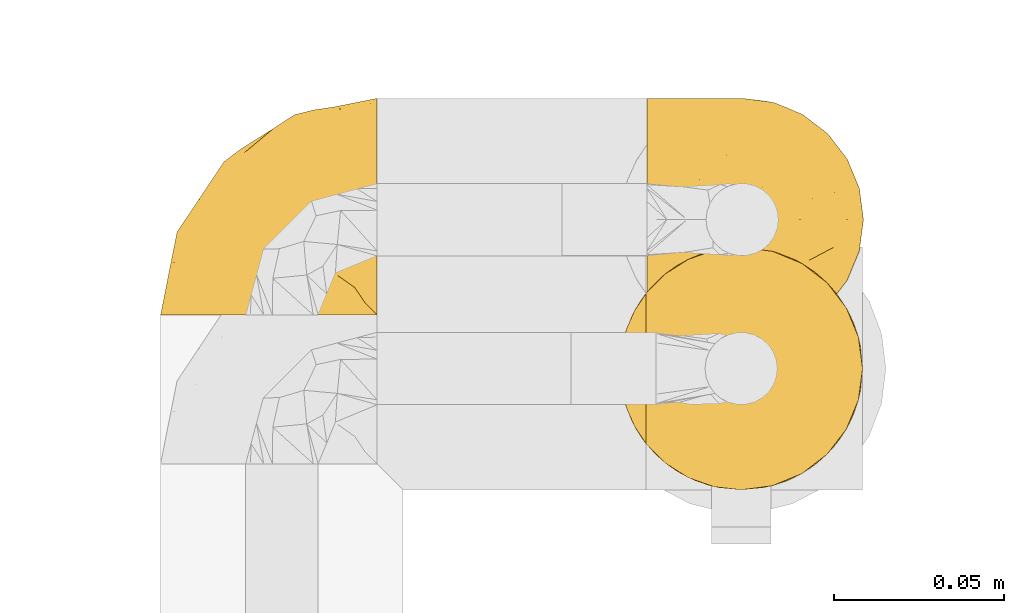
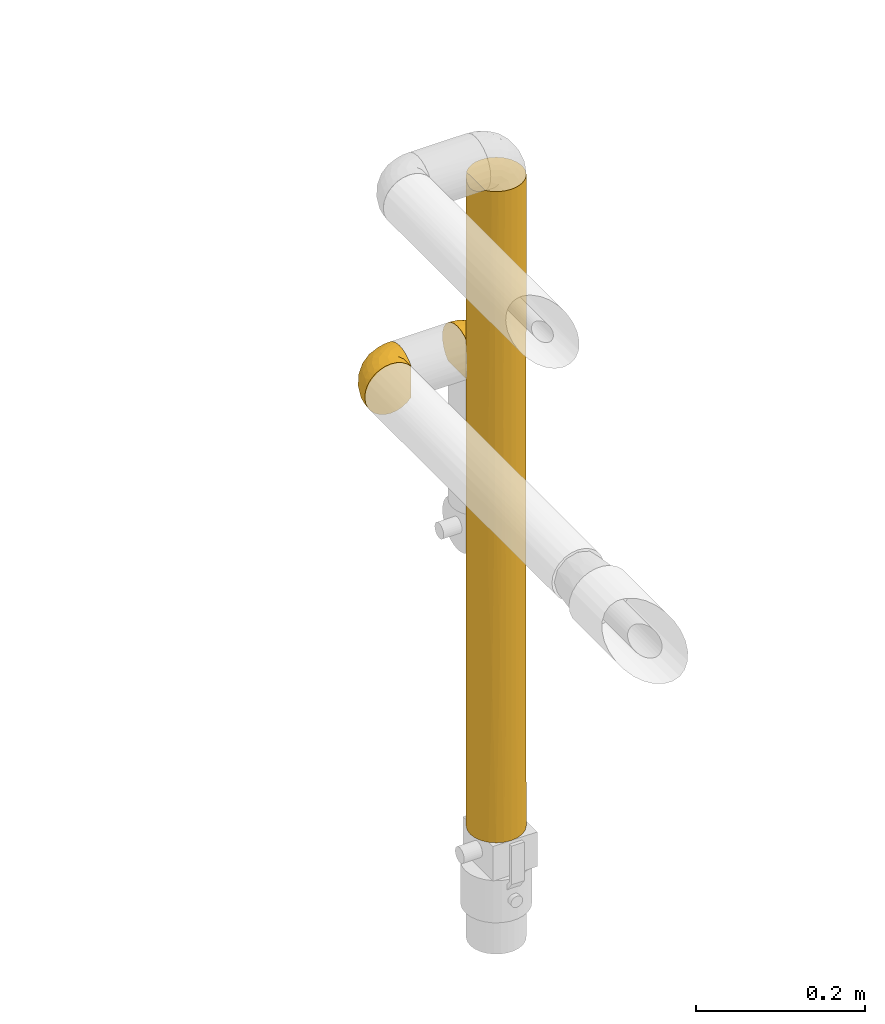
# One storey, part 68 of 827: 3 coverings.
"""IFC2X3 building model written with IfcOpenShell, lengths in millimetres."""

from ifc_helpers import new_model, entity, si_unit, converted_unit, derived_unit, direction, frame, origin, place, context, subcontext, project, spatial, faceted_brep, element, save


model = new_model("IFC2X3")

# Units and contexts
model_context = context("Model", 3, precision=0.01, world=origin(), true_north=direction((6.12303176911189e-17, 1.0)))
body_context = subcontext(model_context, "Body", "Model", "MODEL_VIEW")
ifc_project = project(units=[si_unit("LENGTHUNIT", "METRE", prefix="MILLI"), si_unit("AREAUNIT", "SQUARE_METRE"), si_unit("VOLUMEUNIT", "CUBIC_METRE"), converted_unit("PLANEANGLEUNIT", "DEGREE", entity("IfcRatioMeasure", 0.0174532925199433), si_unit("PLANEANGLEUNIT", "RADIAN"), dimensions=[0, 0, 0, 0, 0, 0, 0]), si_unit("MASSUNIT", "GRAM", prefix="KILO"), derived_unit("MASSDENSITYUNIT", [(si_unit("MASSUNIT", "GRAM", prefix="KILO"), 1), (si_unit("LENGTHUNIT", "METRE"), -3)]), derived_unit("MOMENTOFINERTIAUNIT", [(si_unit("LENGTHUNIT", "METRE"), 4)]), si_unit("TIMEUNIT", "SECOND"), si_unit("FREQUENCYUNIT", "HERTZ"), si_unit("THERMODYNAMICTEMPERATUREUNIT", "DEGREE_CELSIUS"), derived_unit("THERMALTRANSMITTANCEUNIT", [(si_unit("MASSUNIT", "GRAM", prefix="KILO"), 1), (si_unit("THERMODYNAMICTEMPERATUREUNIT", "KELVIN"), -1), (si_unit("TIMEUNIT", "SECOND"), -3)]), derived_unit("VOLUMETRICFLOWRATEUNIT", [(si_unit("LENGTHUNIT", "METRE"), 3), (si_unit("TIMEUNIT", "SECOND"), -1)]), derived_unit("MASSFLOWRATEUNIT", [(si_unit("MASSUNIT", "GRAM", prefix="KILO"), 1), (si_unit("TIMEUNIT", "SECOND"), -1)]), derived_unit("ROTATIONALFREQUENCYUNIT", [(si_unit("TIMEUNIT", "SECOND"), -1)]), si_unit("ELECTRICCURRENTUNIT", "AMPERE"), si_unit("ELECTRICVOLTAGEUNIT", "VOLT"), si_unit("POWERUNIT", "WATT"), si_unit("FORCEUNIT", "NEWTON", prefix="KILO"), si_unit("ILLUMINANCEUNIT", "LUX"), si_unit("LUMINOUSFLUXUNIT", "LUMEN"), si_unit("LUMINOUSINTENSITYUNIT", "CANDELA"), derived_unit("USERDEFINED", [(si_unit("MASSUNIT", "GRAM", prefix="KILO"), -1), (si_unit("LENGTHUNIT", "METRE"), -2), (si_unit("TIMEUNIT", "SECOND"), 3), (si_unit("LUMINOUSFLUXUNIT", "LUMEN"), 1)]), derived_unit("LINEARVELOCITYUNIT", [(si_unit("LENGTHUNIT", "METRE"), 1), (si_unit("TIMEUNIT", "SECOND"), -1)]), si_unit("PRESSUREUNIT", "PASCAL"), derived_unit("USERDEFINED", [(si_unit("LENGTHUNIT", "METRE"), -2), (si_unit("MASSUNIT", "GRAM", prefix="KILO"), 1), (si_unit("TIMEUNIT", "SECOND"), -2)]), derived_unit("LINEARFORCEUNIT", [(si_unit("MASSUNIT", "GRAM", prefix="KILO"), 1), (si_unit("LENGTHUNIT", "METRE"), 1), (si_unit("TIMEUNIT", "SECOND"), -2), (si_unit("LENGTHUNIT", "METRE"), -1)]), derived_unit("PLANARFORCEUNIT", [(si_unit("MASSUNIT", "GRAM", prefix="KILO"), 1), (si_unit("LENGTHUNIT", "METRE"), 1), (si_unit("TIMEUNIT", "SECOND"), -2), (si_unit("LENGTHUNIT", "METRE"), -2)])], contexts=[model_context])

# Site, building, storey
site_placement = place(None, origin())
site = spatial("IfcSite", under=ifc_project, at=site_placement, CompositionType="ELEMENT")
building_placement = place(site_placement, origin())
building = spatial("IfcBuilding", under=site, at=building_placement, CompositionType="ELEMENT")
storey_placement = place(building_placement, frame((0.0, 0.0, 28200.0)))
storey = spatial("IfcBuildingStorey", under=building, at=storey_placement, Name="08", CompositionType="ELEMENT", Elevation=28200.0)

# Coverings
covering_1_placement = place(storey_placement, frame((13380.77, 12385.32, 970.4)))
element("IfcCovering", 1, at=covering_1_placement, inside=storey, Name=":ADSK_", ObjectType=":ADSK_", PredefinedType="INSULATION", context=body_context, shape_type="Brep", body=[
    faceted_brep([(1.6, 5.13, 45.07), (1.6, 9.38, 51.83), (1.6, 15.03, 57.48), (1.6, 21.79, 61.72), (1.6, 29.32, 64.36), (1.6, 37.25, 65.25), (1.6, 45.19, 64.35), (1.6, 52.72, 61.71), (1.6, 59.48, 57.46), (1.6, 65.12, 51.82), (1.6, 69.37, 45.06), (1.6, 72.0, 37.52), (1.6, 72.9, 29.6), (1.6, 72.01, 21.69), (1.6, 69.39, 14.19), (1.6, 65.18, 7.45), (1.6, 59.59, 1.82), (1.6, 57.53, 1.82), (1.6, 56.06, 1.82), (1.6, 54.3, 1.82), (1.6, 52.53, 1.82), (1.6, 50.77, 1.82), (1.6, 49.0, 1.82), (1.6, 47.24, 1.82), (1.6, 45.47, 1.82), (1.6, 43.71, 1.82), (1.6, 41.94, 1.82), (1.6, 40.18, 1.82), (1.6, 38.41, 1.82), (1.6, 36.65, 1.82), (1.6, 34.88, 1.82), (1.6, 33.12, 1.82), (1.6, 31.35, 1.82), (1.6, 29.3, 1.82), (1.6, 27.24, 1.82), (1.6, 25.18, 1.82), (1.6, 23.13, 1.82), (1.6, 21.07, 1.82), (1.6, 19.01, 1.82), (1.6, 16.96, 1.82), (1.6, 14.9, 1.82), (1.6, 9.3, 7.46), (1.6, 5.09, 14.21), (1.6, 2.48, 21.71), (1.6, 1.6, 29.6), (1.6, 2.49, 37.54), (1.82, 59.59, 1.6), (7.46, 65.19, 1.6), (14.2, 69.4, 1.6), (21.7, 72.01, 1.6), (29.6, 72.9, 1.6), (38.82, 71.68, 1.6), (47.42, 68.12, 1.6), (54.8, 62.45, 1.6), (60.47, 55.07, 1.6), (64.03, 46.47, 1.6), (65.25, 37.25, 1.6), (64.03, 28.02, 1.6), (60.47, 19.42, 1.6), (54.8, 12.04, 1.6), (47.42, 6.37, 1.6), (38.82, 2.81, 1.6), (29.6, 1.6, 1.6), (21.7, 2.48, 1.6), (14.2, 5.09, 1.6), (7.46, 9.3, 1.6), (1.82, 14.9, 1.6), (1.82, 15.93, 1.6), (1.82, 17.69, 1.6), (1.82, 19.09, 1.6), (1.82, 20.49, 1.6), (1.82, 21.88, 1.6), (1.82, 23.28, 1.6), (1.82, 24.68, 1.6), (1.82, 26.07, 1.6), (1.82, 27.47, 1.6), (1.82, 28.87, 1.6), (1.82, 30.26, 1.6), (1.82, 31.66, 1.6), (1.82, 33.06, 1.6), (1.82, 34.45, 1.6), (1.82, 35.85, 1.6), (1.82, 37.25, 1.6), (1.82, 39.01, 1.6), (1.82, 40.77, 1.6), (1.82, 42.54, 1.6), (1.82, 44.3, 1.6), (1.82, 46.07, 1.6), (1.82, 47.83, 1.6), (1.82, 49.6, 1.6), (1.82, 51.36, 1.6), (1.82, 53.42, 1.6), (1.82, 55.48, 1.6), (1.82, 57.53, 1.6), (1.75, 24.13, 1.76), (1.76, 22.58, 1.75), (1.76, 46.76, 1.75), (1.76, 45.43, 1.75), (1.74, 51.49, 1.76), (1.76, 35.2, 1.75), (1.75, 58.19, 1.75), (1.75, 56.8, 1.75), (1.75, 32.4, 1.75), (1.76, 30.96, 1.75), (1.74, 16.26, 1.76), (1.75, 14.9, 1.76), (1.74, 28.17, 1.76), (1.76, 26.81, 1.75), (1.75, 55.49, 1.76), (1.75, 44.1, 1.76), (1.74, 42.83, 1.77), (1.76, 36.55, 1.74), (1.76, 37.92, 1.75), (1.76, 29.48, 1.75), (1.73, 39.3, 1.77), (1.74, 48.12, 1.77), (1.75, 49.39, 1.76), (1.74, 17.58, 1.76), (1.75, 33.81, 1.76), (1.78, 41.72, 1.72), (1.76, 54.15, 1.74), (1.76, 52.82, 1.75), (1.75, 40.57, 1.76), (1.76, 21.1, 1.75), (1.75, 19.79, 1.76), (1.75, 59.59, 1.75), (1.76, 25.46, 1.75), (13.11, 70.91, 13.1), (8.18, 68.25, 9.65), (25.84, 72.9, 15.6), (28.13, 72.9, 7.07), (15.6, 72.9, 25.84), (5.2, 64.57, 5.2), (20.72, 72.9, 20.72), (7.07, 72.9, 28.13), (35.56, 46.9, 53.84), (16.98, 49.03, 61.29), (25.95, 37.25, 60.4), (35.4, 72.16, 11.45), (32.74, 72.13, 18.37), (43.51, 65.96, 27.21), (53.51, 58.95, 23.34), (49.6, 65.53, 14.46), (40.07, 70.18, 17.53), (42.61, 70.18, 8.83), (20.45, 67.44, 44.61), (10.52, 67.44, 47.7), (14.87, 62.46, 53.12), (24.92, 72.2, 27.74), (34.61, 53.36, 51.46), (61.84, 43.86, 20.14), (60.43, 50.89, 17.45), (14.29, 37.25, 62.72), (57.0, 58.95, 11.49), (42.79, 55.84, 43.01), (33.34, 59.2, 47.84), (21.53, 71.35, 34.4), (11.52, 70.9, 40.11), (12.66, 56.22, 58.72), (34.11, 67.43, 35.5), (32.29, 70.63, 28.03), (24.41, 61.46, 50.73), (24.95, 56.22, 54.88), (44.19, 48.22, 46.54), (56.24, 51.43, 28.04), (56.83, 45.24, 31.36), (50.94, 50.08, 37.9), (50.38, 43.45, 41.63), (46.6, 37.25, 46.6), (36.28, 37.25, 53.5), (62.72, 37.25, 14.29), (47.39, 59.41, 33.68), (38.92, 62.46, 39.51), (29.55, 64.67, 43.99), (26.82, 68.36, 39.36), (60.4, 37.25, 25.96), (53.5, 37.25, 36.28), (41.8, 4.31, 12.43), (61.8, 30.45, 20.13), (49.33, 25.32, 40.53), (35.54, 27.6, 53.86), (14.87, 12.05, 53.13), (12.65, 18.29, 58.73), (47.44, 8.96, 20.81), (56.06, 15.54, 15.78), (50.17, 16.32, 31.16), (20.44, 7.07, 44.62), (10.52, 7.07, 47.72), (11.52, 3.6, 40.12), (38.79, 19.36, 47.19), (33.87, 2.28, 14.97), (25.84, 1.6, 15.6), (27.72, 1.6, 8.6), (7.07, 1.6, 28.13), (62.13, 25.07, 12.48), (50.52, 8.96, 10.34), (56.47, 29.09, 31.94), (58.39, 23.6, 23.68), (16.98, 25.48, 61.3), (39.3, 7.69, 31.19), (38.56, 4.1, 19.63), (24.94, 18.29, 54.9), (30.34, 2.18, 20.58), (26.49, 2.39, 26.9), (15.6, 1.6, 25.85), (20.72, 1.6, 20.72), (26.6, 12.04, 48.57), (21.54, 3.15, 34.41), (35.7, 2.24, 8.15), (38.91, 12.04, 39.53), (30.65, 6.5, 37.32), (44.9, 11.64, 31.82), (34.09, 3.92, 26.03), (13.11, 3.58, 13.11), (9.65, 6.24, 8.18), (5.2, 9.92, 5.21)], [[[0, 1, 2, 3, 4, 5, 6, 7, 8, 9, 10, 11, 12, 13, 14, 15, 16, 17, 18, 19, 20, 21, 22, 23, 24, 25, 26, 27, 28, 29, 30, 31, 32, 33, 34, 35, 36, 37, 38, 39, 40, 41, 42, 43, 44, 45]], [[46, 47, 48, 49, 50, 51, 52, 53, 54, 55, 56, 57, 58, 59, 60, 61, 62, 63, 64, 65, 66, 67, 68, 69, 70, 71, 72, 73, 74, 75, 76, 77, 78, 79, 80, 81, 82, 83, 84, 85, 86, 87, 88, 89, 90, 91, 92, 93]], [[94, 72, 95]], [[96, 87, 97]], [[20, 98, 21]], [[99, 81, 80]], [[100, 93, 101]], [[102, 103, 32]], [[104, 105, 40]], [[67, 105, 104]], [[106, 107, 34]], [[18, 101, 108]], [[109, 85, 110]], [[36, 94, 95]], [[81, 111, 82]], [[29, 28, 112]], [[17, 101, 18]], [[103, 113, 33]], [[24, 96, 97]], [[28, 114, 112]], [[115, 22, 116]], [[31, 102, 32]], [[68, 104, 117]], [[31, 118, 102]], [[84, 119, 85]], [[120, 91, 121]], [[23, 22, 115]], [[114, 27, 122]], [[123, 37, 95]], [[117, 124, 69]], [[67, 66, 105]], [[104, 39, 117]], [[123, 124, 37]], [[100, 17, 16]], [[100, 125, 46]], [[17, 100, 101]], [[107, 126, 35]], [[92, 108, 101]], [[115, 88, 96]], [[114, 122, 83]], [[101, 93, 92]], [[93, 100, 46]], [[16, 125, 100]], [[108, 19, 18]], [[120, 121, 19]], [[108, 92, 120]], [[19, 108, 120]], [[67, 104, 68]], [[39, 104, 40]], [[69, 68, 117]], [[117, 39, 38]], [[70, 124, 123]], [[124, 70, 69]], [[38, 124, 117]], [[124, 38, 37]], [[72, 71, 95]], [[71, 123, 95]], [[71, 70, 123]], [[126, 94, 35]], [[37, 36, 95]], [[75, 74, 107]], [[73, 72, 94]], [[94, 36, 35]], [[94, 126, 73]], [[74, 73, 126]], [[106, 76, 75]], [[76, 106, 113]], [[113, 106, 33]], [[107, 35, 34]], [[106, 34, 33]], [[126, 107, 74]], [[107, 106, 75]], [[78, 77, 103]], [[77, 113, 103]], [[77, 76, 113]], [[102, 78, 103]], [[33, 32, 103]], [[80, 79, 118]], [[102, 118, 79]], [[112, 111, 29]], [[118, 31, 30]], [[79, 78, 102]], [[99, 111, 81]], [[112, 82, 111]], [[111, 99, 29]], [[30, 29, 99]], [[112, 83, 82]], [[27, 114, 28]], [[99, 118, 30]], [[118, 99, 80]], [[114, 83, 112]], [[84, 83, 122]], [[109, 110, 25]], [[122, 27, 26]], [[119, 110, 85]], [[20, 19, 121]], [[25, 110, 26]], [[91, 120, 92]], [[90, 98, 121]], [[121, 91, 90]], [[23, 115, 96]], [[88, 115, 116]], [[116, 98, 89]], [[89, 88, 116]], [[23, 96, 24]], [[87, 96, 88]], [[25, 24, 109]], [[97, 87, 86]], [[90, 89, 98]], [[116, 22, 21]], [[122, 26, 119]], [[86, 85, 109]], [[109, 97, 86]], [[97, 109, 24]], [[110, 119, 26]], [[122, 119, 84]], [[121, 98, 20]], [[21, 98, 116]], [[48, 127, 49]], [[48, 47, 128]], [[49, 129, 130, 50]], [[129, 49, 127]], [[131, 127, 13]], [[46, 125, 132]], [[16, 15, 132]], [[127, 128, 14]], [[127, 131, 133, 129]], [[14, 13, 127]], [[13, 12, 134, 131]], [[46, 132, 47]], [[48, 128, 127]], [[47, 132, 128]], [[15, 128, 132]], [[125, 16, 132]], [[15, 14, 128]], [[135, 136, 137]], [[138, 129, 139]], [[140, 141, 142]], [[143, 144, 138]], [[145, 146, 147]], [[133, 148, 139]], [[134, 12, 11]], [[136, 135, 149]], [[150, 55, 151]], [[136, 6, 152]], [[153, 54, 53]], [[52, 144, 142]], [[52, 142, 53]], [[54, 153, 151]], [[144, 52, 51]], [[154, 155, 149]], [[156, 131, 157]], [[134, 11, 157]], [[8, 7, 158]], [[147, 9, 8]], [[157, 131, 134]], [[157, 11, 10]], [[146, 157, 10]], [[159, 140, 160]], [[157, 145, 156]], [[161, 162, 155]], [[161, 147, 162]], [[154, 149, 163]], [[150, 164, 165]], [[136, 7, 6]], [[137, 136, 152]], [[162, 158, 136]], [[54, 151, 55]], [[158, 147, 8]], [[166, 167, 165]], [[9, 146, 10]], [[164, 166, 165]], [[168, 135, 137, 169]], [[55, 150, 170]], [[154, 171, 172]], [[139, 148, 160]], [[140, 142, 143]], [[153, 142, 141]], [[51, 50, 130]], [[145, 173, 174]], [[156, 160, 148]], [[6, 5, 152]], [[136, 158, 7]], [[147, 158, 162]], [[147, 146, 9]], [[157, 146, 145]], [[160, 140, 143]], [[140, 172, 171]], [[139, 143, 138]], [[173, 159, 174]], [[170, 150, 175]], [[170, 56, 55]], [[167, 168, 176]], [[176, 175, 165]], [[150, 165, 175]], [[163, 167, 166]], [[176, 165, 167]], [[164, 150, 151]], [[151, 141, 164]], [[171, 164, 141]], [[154, 163, 166]], [[163, 135, 168]], [[166, 164, 171]], [[155, 154, 172]], [[166, 171, 154]], [[140, 171, 141]], [[173, 155, 172]], [[149, 155, 162]], [[159, 173, 172]], [[161, 145, 147]], [[140, 159, 172]], [[174, 160, 156]], [[136, 149, 162]], [[149, 135, 163]], [[155, 173, 161]], [[145, 161, 173]], [[160, 174, 159]], [[156, 148, 131]], [[156, 145, 174]], [[142, 153, 53]], [[151, 153, 141]], [[138, 51, 130]], [[142, 144, 143]], [[51, 138, 144]], [[129, 138, 130]], [[133, 139, 129]], [[160, 143, 139]], [[168, 167, 163]], [[131, 148, 133]], [[60, 177, 61]], [[175, 178, 170]], [[179, 168, 180]], [[178, 57, 170]], [[181, 182, 2]], [[183, 184, 185]], [[186, 187, 188]], [[189, 185, 179]], [[190, 191, 192]], [[45, 193, 188]], [[194, 184, 58]], [[45, 44, 193]], [[59, 195, 60]], [[60, 195, 177]], [[0, 45, 188]], [[196, 179, 197]], [[180, 137, 198]], [[183, 199, 200]], [[201, 182, 181]], [[1, 181, 2]], [[57, 178, 194]], [[198, 3, 182]], [[198, 152, 4]], [[1, 0, 187]], [[190, 202, 191]], [[203, 204, 205]], [[206, 201, 181]], [[186, 188, 207]], [[188, 204, 207]], [[3, 198, 4]], [[58, 184, 59]], [[187, 181, 1]], [[180, 198, 201]], [[206, 181, 186]], [[180, 189, 179]], [[3, 2, 182]], [[180, 168, 169, 137]], [[204, 188, 193]], [[177, 190, 208]], [[209, 210, 199]], [[210, 186, 207]], [[185, 184, 197]], [[195, 184, 183]], [[205, 202, 203]], [[210, 209, 206]], [[179, 185, 197]], [[211, 209, 199]], [[196, 197, 178]], [[180, 201, 189]], [[152, 198, 137]], [[152, 5, 4]], [[61, 208, 62]], [[198, 182, 201]], [[188, 187, 0]], [[181, 187, 186]], [[203, 210, 207]], [[202, 205, 191]], [[199, 210, 212]], [[57, 56, 170]], [[176, 196, 175]], [[178, 197, 194]], [[179, 176, 168]], [[175, 196, 178]], [[176, 179, 196]], [[184, 194, 197]], [[58, 57, 194]], [[208, 190, 192]], [[200, 190, 177]], [[206, 189, 201]], [[185, 189, 209]], [[62, 208, 192]], [[177, 208, 61]], [[210, 206, 186]], [[189, 206, 209]], [[200, 199, 212]], [[211, 183, 185]], [[184, 195, 59]], [[177, 195, 183]], [[183, 200, 177]], [[202, 200, 212]], [[200, 202, 190]], [[202, 212, 203]], [[210, 203, 212]], [[204, 203, 207]], [[183, 211, 199]], [[185, 209, 211]], [[63, 62, 192, 191]], [[64, 63, 213]], [[64, 213, 214]], [[65, 215, 66]], [[213, 191, 205, 204]], [[43, 204, 193, 44]], [[65, 214, 215]], [[42, 213, 43]], [[215, 105, 66]], [[41, 214, 42]], [[40, 105, 215]], [[65, 64, 214]], [[40, 215, 41]], [[213, 63, 191]], [[42, 214, 213]], [[204, 43, 213]], [[214, 41, 215]]]),
])
covering_2_placement = place(storey_placement, frame((13237.87, 12392.97, 962.76)))
element("IfcCovering", 2, at=covering_2_placement, inside=storey, Name=":ADSK_", ObjectType=":ADSK_", PredefinedType="INSULATION", context=body_context, shape_type="Brep", body=[
    faceted_brep([(21.77, 1.6, 69.36), (15.01, 1.6, 65.11), (9.37, 1.6, 59.47), (5.12, 1.6, 52.71), (2.49, 1.6, 45.17), (1.6, 1.6, 37.25), (2.49, 1.6, 29.31), (5.13, 1.6, 21.77), (9.38, 1.6, 15.01), (15.02, 1.6, 9.37), (21.78, 1.6, 5.12), (29.32, 1.6, 2.49), (37.25, 1.6, 1.6), (45.15, 1.6, 2.48), (52.65, 1.6, 5.1), (59.39, 1.6, 9.31), (65.02, 1.6, 14.9), (65.02, 1.6, 16.96), (65.02, 1.6, 18.43), (65.02, 1.6, 20.19), (65.02, 1.6, 21.96), (65.02, 1.6, 23.72), (65.02, 1.6, 25.49), (65.02, 1.6, 27.25), (65.02, 1.6, 29.02), (65.02, 1.6, 30.78), (65.02, 1.6, 32.55), (65.02, 1.6, 34.31), (65.02, 1.6, 36.08), (65.02, 1.6, 37.84), (65.02, 1.6, 39.61), (65.02, 1.6, 41.37), (65.02, 1.6, 43.14), (65.02, 1.6, 45.19), (65.02, 1.6, 47.25), (65.02, 1.6, 49.31), (65.02, 1.6, 51.36), (65.02, 1.6, 53.42), (65.02, 1.6, 55.48), (65.02, 1.6, 57.53), (65.02, 1.6, 59.59), (59.38, 1.6, 65.19), (52.64, 1.6, 69.4), (45.13, 1.6, 72.01), (37.25, 1.6, 72.9), (29.31, 1.6, 72.0), (65.25, 1.82, 14.9), (65.25, 7.46, 9.3), (65.25, 14.2, 5.09), (65.25, 21.7, 2.48), (65.25, 29.6, 1.6), (65.25, 38.82, 2.81), (65.25, 47.42, 6.37), (65.25, 54.8, 12.04), (65.25, 60.47, 19.42), (65.25, 64.03, 28.02), (65.25, 65.25, 37.25), (65.25, 64.03, 46.47), (65.25, 60.47, 55.07), (65.25, 54.8, 62.45), (65.25, 47.42, 68.12), (65.25, 38.82, 71.68), (65.25, 29.6, 72.9), (65.25, 21.7, 72.01), (65.25, 14.2, 69.4), (65.25, 7.46, 65.19), (65.25, 1.82, 59.59), (65.25, 1.82, 58.56), (65.25, 1.82, 56.8), (65.25, 1.82, 55.4), (65.25, 1.82, 54.0), (65.25, 1.82, 52.61), (65.25, 1.82, 51.21), (65.25, 1.82, 49.81), (65.25, 1.82, 48.42), (65.25, 1.82, 47.02), (65.25, 1.82, 45.62), (65.25, 1.82, 44.23), (65.25, 1.82, 42.83), (65.25, 1.82, 41.43), (65.25, 1.82, 40.04), (65.25, 1.82, 38.64), (65.25, 1.82, 37.25), (65.25, 1.82, 35.48), (65.25, 1.82, 33.72), (65.25, 1.82, 31.95), (65.25, 1.82, 30.19), (65.25, 1.82, 28.42), (65.25, 1.82, 26.66), (65.25, 1.82, 24.89), (65.25, 1.82, 23.13), (65.25, 1.82, 21.07), (65.25, 1.82, 19.01), (65.25, 1.82, 16.96), (65.08, 1.75, 50.36), (65.09, 1.76, 51.91), (65.09, 1.76, 27.73), (65.1, 1.76, 29.06), (65.08, 1.74, 23.0), (65.09, 1.76, 39.29), (65.09, 1.75, 16.3), (65.09, 1.75, 17.69), (65.09, 1.75, 42.09), (65.1, 1.76, 43.53), (65.08, 1.74, 58.23), (65.09, 1.75, 59.59), (65.08, 1.74, 46.32), (65.09, 1.76, 47.68), (65.08, 1.75, 19.0), (65.09, 1.75, 30.39), (65.07, 1.74, 31.67), (65.1, 1.76, 37.94), (65.09, 1.76, 36.57), (65.1, 1.76, 45.01), (65.07, 1.73, 35.19), (65.07, 1.74, 26.37), (65.09, 1.75, 25.1), (65.08, 1.74, 56.91), (65.09, 1.75, 40.68), (65.13, 1.78, 32.77), (65.1, 1.76, 20.34), (65.09, 1.76, 21.67), (65.09, 1.75, 33.92), (65.1, 1.76, 53.39), (65.09, 1.75, 54.7), (65.09, 1.75, 14.9), (65.09, 1.76, 49.03), (53.74, 13.11, 3.58), (57.19, 8.18, 6.24), (51.25, 25.84, 1.6), (59.77, 28.13, 1.6), (41.0, 15.6, 1.6), (61.64, 5.2, 9.92), (46.12, 20.72, 1.6), (38.71, 7.07, 1.6), (13.0, 35.56, 27.59), (5.55, 16.98, 25.47), (6.44, 25.95, 37.25), (55.39, 35.4, 2.33), (48.48, 32.74, 2.37), (39.63, 43.51, 8.53), (43.5, 53.51, 15.54), (52.38, 49.6, 8.96), (49.31, 40.07, 4.31), (58.01, 42.61, 4.31), (22.23, 20.45, 7.06), (19.14, 10.52, 7.06), (13.73, 14.87, 12.03), (39.1, 24.92, 2.3), (15.38, 34.61, 21.13), (46.7, 61.84, 30.63), (49.4, 60.43, 23.6), (4.12, 14.29, 37.25), (55.35, 57.0, 15.54), (23.83, 42.79, 18.65), (19.0, 33.34, 15.3), (32.44, 21.53, 3.14), (26.73, 11.52, 3.59), (8.12, 12.66, 18.27), (31.34, 34.11, 7.07), (38.81, 32.29, 3.86), (16.11, 24.41, 13.04), (11.96, 24.95, 18.27), (20.31, 44.19, 26.27), (38.81, 56.24, 23.06), (35.48, 56.83, 29.25), (28.94, 50.94, 24.41), (25.21, 50.38, 31.04), (20.24, 46.6, 37.25), (13.34, 36.28, 37.25), (52.55, 62.72, 37.25), (33.16, 47.39, 15.08), (27.33, 38.92, 12.03), (22.86, 29.55, 9.82), (27.48, 26.82, 6.14), (40.89, 60.4, 37.25), (30.56, 53.5, 37.25), (54.41, 41.8, 70.18), (46.71, 61.8, 44.04), (26.31, 49.33, 49.17), (12.98, 35.54, 46.9), (13.72, 14.87, 62.45), (8.12, 12.65, 56.21), (46.04, 47.44, 65.53), (51.06, 56.06, 58.95), (35.69, 50.17, 58.17), (22.22, 20.44, 67.43), (19.13, 10.52, 67.43), (26.72, 11.52, 70.89), (19.65, 38.79, 55.13), (51.87, 33.87, 72.21), (51.25, 25.84, 72.9), (58.25, 27.72, 72.9), (38.71, 7.07, 72.9), (54.36, 62.13, 49.42), (56.5, 50.52, 65.53), (34.9, 56.47, 45.41), (43.16, 58.39, 50.89), (5.54, 16.98, 49.01), (35.66, 39.3, 66.8), (47.21, 38.56, 70.39), (11.95, 24.94, 56.21), (46.27, 30.34, 72.31), (39.95, 26.49, 72.1), (41.0, 15.6, 72.9), (46.12, 20.72, 72.9), (18.27, 26.6, 62.45), (32.43, 21.54, 71.35), (58.69, 35.7, 72.26), (27.31, 38.91, 62.45), (29.52, 30.65, 67.99), (35.02, 44.9, 62.85), (40.81, 34.09, 70.57), (53.74, 13.11, 70.91), (58.66, 9.65, 68.25), (61.64, 5.2, 64.57)], [[[0, 1, 2, 3, 4, 5, 6, 7, 8, 9, 10, 11, 12, 13, 14, 15, 16, 17, 18, 19, 20, 21, 22, 23, 24, 25, 26, 27, 28, 29, 30, 31, 32, 33, 34, 35, 36, 37, 38, 39, 40, 41, 42, 43, 44, 45]], [[46, 47, 48, 49, 50, 51, 52, 53, 54, 55, 56, 57, 58, 59, 60, 61, 62, 63, 64, 65, 66, 67, 68, 69, 70, 71, 72, 73, 74, 75, 76, 77, 78, 79, 80, 81, 82, 83, 84, 85, 86, 87, 88, 89, 90, 91, 92, 93]], [[94, 72, 95]], [[96, 87, 97]], [[20, 98, 21]], [[99, 81, 80]], [[100, 93, 101]], [[102, 103, 32]], [[104, 105, 40]], [[67, 105, 104]], [[106, 107, 34]], [[18, 101, 108]], [[109, 85, 110]], [[36, 94, 95]], [[81, 111, 82]], [[29, 28, 112]], [[17, 101, 18]], [[103, 113, 33]], [[24, 96, 97]], [[28, 114, 112]], [[115, 22, 116]], [[31, 102, 32]], [[68, 104, 117]], [[31, 118, 102]], [[84, 119, 85]], [[120, 91, 121]], [[23, 22, 115]], [[114, 27, 122]], [[123, 37, 95]], [[117, 124, 69]], [[67, 66, 105]], [[104, 39, 117]], [[123, 124, 37]], [[100, 17, 16]], [[100, 125, 46]], [[17, 100, 101]], [[107, 126, 35]], [[92, 108, 101]], [[115, 88, 96]], [[114, 122, 83]], [[101, 93, 92]], [[93, 100, 46]], [[16, 125, 100]], [[108, 19, 18]], [[120, 121, 19]], [[108, 92, 120]], [[19, 108, 120]], [[67, 104, 68]], [[39, 104, 40]], [[69, 68, 117]], [[117, 39, 38]], [[70, 124, 123]], [[124, 70, 69]], [[38, 124, 117]], [[124, 38, 37]], [[72, 71, 95]], [[71, 123, 95]], [[71, 70, 123]], [[126, 94, 35]], [[37, 36, 95]], [[75, 74, 107]], [[73, 72, 94]], [[94, 36, 35]], [[94, 126, 73]], [[74, 73, 126]], [[106, 76, 75]], [[76, 106, 113]], [[113, 106, 33]], [[107, 35, 34]], [[106, 34, 33]], [[126, 107, 74]], [[107, 106, 75]], [[78, 77, 103]], [[77, 113, 103]], [[77, 76, 113]], [[102, 78, 103]], [[33, 32, 103]], [[80, 79, 118]], [[102, 118, 79]], [[112, 111, 29]], [[118, 31, 30]], [[79, 78, 102]], [[99, 111, 81]], [[112, 82, 111]], [[111, 99, 29]], [[30, 29, 99]], [[112, 83, 82]], [[27, 114, 28]], [[99, 118, 30]], [[118, 99, 80]], [[114, 83, 112]], [[84, 83, 122]], [[109, 110, 25]], [[122, 27, 26]], [[119, 110, 85]], [[20, 19, 121]], [[25, 110, 26]], [[91, 120, 92]], [[90, 98, 121]], [[121, 91, 90]], [[23, 115, 96]], [[88, 115, 116]], [[116, 98, 89]], [[89, 88, 116]], [[23, 96, 24]], [[87, 96, 88]], [[25, 24, 109]], [[97, 87, 86]], [[90, 89, 98]], [[116, 22, 21]], [[122, 26, 119]], [[86, 85, 109]], [[109, 97, 86]], [[97, 109, 24]], [[110, 119, 26]], [[122, 119, 84]], [[121, 98, 20]], [[21, 98, 116]], [[48, 127, 49]], [[48, 47, 128]], [[49, 129, 130, 50]], [[129, 49, 127]], [[131, 127, 13]], [[46, 125, 132]], [[16, 15, 132]], [[127, 128, 14]], [[127, 131, 133, 129]], [[14, 13, 127]], [[13, 12, 134, 131]], [[46, 132, 47]], [[48, 128, 127]], [[47, 132, 128]], [[15, 128, 132]], [[125, 16, 132]], [[15, 14, 128]], [[135, 136, 137]], [[138, 129, 139]], [[140, 141, 142]], [[143, 144, 138]], [[145, 146, 147]], [[133, 148, 139]], [[134, 12, 11]], [[136, 135, 149]], [[150, 55, 151]], [[136, 6, 152]], [[153, 54, 53]], [[52, 144, 142]], [[52, 142, 53]], [[54, 153, 151]], [[144, 52, 51]], [[154, 155, 149]], [[156, 131, 157]], [[134, 11, 157]], [[8, 7, 158]], [[147, 9, 8]], [[157, 131, 134]], [[157, 11, 10]], [[146, 157, 10]], [[159, 140, 160]], [[157, 145, 156]], [[161, 162, 155]], [[161, 147, 162]], [[154, 149, 163]], [[150, 164, 165]], [[136, 7, 6]], [[137, 136, 152]], [[162, 158, 136]], [[54, 151, 55]], [[158, 147, 8]], [[166, 167, 165]], [[9, 146, 10]], [[164, 166, 165]], [[168, 135, 137, 169]], [[55, 150, 170]], [[154, 171, 172]], [[139, 148, 160]], [[140, 142, 143]], [[153, 142, 141]], [[51, 50, 130]], [[145, 173, 174]], [[156, 160, 148]], [[6, 5, 152]], [[136, 158, 7]], [[147, 158, 162]], [[147, 146, 9]], [[157, 146, 145]], [[160, 140, 143]], [[140, 172, 171]], [[139, 143, 138]], [[173, 159, 174]], [[170, 150, 175]], [[170, 56, 55]], [[167, 168, 176]], [[176, 175, 165]], [[150, 165, 175]], [[163, 167, 166]], [[176, 165, 167]], [[164, 150, 151]], [[151, 141, 164]], [[171, 164, 141]], [[154, 163, 166]], [[163, 135, 168]], [[166, 164, 171]], [[155, 154, 172]], [[166, 171, 154]], [[140, 171, 141]], [[173, 155, 172]], [[149, 155, 162]], [[159, 173, 172]], [[161, 145, 147]], [[140, 159, 172]], [[174, 160, 156]], [[136, 149, 162]], [[149, 135, 163]], [[155, 173, 161]], [[145, 161, 173]], [[160, 174, 159]], [[156, 148, 131]], [[156, 145, 174]], [[142, 153, 53]], [[151, 153, 141]], [[138, 51, 130]], [[142, 144, 143]], [[51, 138, 144]], [[129, 138, 130]], [[133, 139, 129]], [[160, 143, 139]], [[168, 167, 163]], [[131, 148, 133]], [[60, 177, 61]], [[175, 178, 170]], [[179, 168, 180]], [[178, 57, 170]], [[181, 182, 2]], [[183, 184, 185]], [[186, 187, 188]], [[189, 185, 179]], [[190, 191, 192]], [[45, 193, 188]], [[194, 184, 58]], [[45, 44, 193]], [[59, 195, 60]], [[60, 195, 177]], [[0, 45, 188]], [[196, 179, 197]], [[180, 137, 198]], [[183, 199, 200]], [[201, 182, 181]], [[1, 181, 2]], [[57, 178, 194]], [[198, 3, 182]], [[198, 152, 4]], [[1, 0, 187]], [[190, 202, 191]], [[203, 204, 205]], [[206, 201, 181]], [[186, 188, 207]], [[188, 204, 207]], [[3, 198, 4]], [[58, 184, 59]], [[187, 181, 1]], [[180, 198, 201]], [[206, 181, 186]], [[180, 189, 179]], [[3, 2, 182]], [[180, 168, 169, 137]], [[204, 188, 193]], [[177, 190, 208]], [[209, 210, 199]], [[210, 186, 207]], [[185, 184, 197]], [[195, 184, 183]], [[205, 202, 203]], [[210, 209, 206]], [[179, 185, 197]], [[211, 209, 199]], [[196, 197, 178]], [[180, 201, 189]], [[152, 198, 137]], [[152, 5, 4]], [[61, 208, 62]], [[198, 182, 201]], [[188, 187, 0]], [[181, 187, 186]], [[203, 210, 207]], [[202, 205, 191]], [[199, 210, 212]], [[57, 56, 170]], [[176, 196, 175]], [[178, 197, 194]], [[179, 176, 168]], [[175, 196, 178]], [[176, 179, 196]], [[184, 194, 197]], [[58, 57, 194]], [[208, 190, 192]], [[200, 190, 177]], [[206, 189, 201]], [[185, 189, 209]], [[62, 208, 192]], [[177, 208, 61]], [[210, 206, 186]], [[189, 206, 209]], [[200, 199, 212]], [[211, 183, 185]], [[184, 195, 59]], [[177, 195, 183]], [[183, 200, 177]], [[202, 200, 212]], [[200, 202, 190]], [[202, 212, 203]], [[210, 203, 212]], [[204, 203, 207]], [[183, 211, 199]], [[185, 209, 211]], [[63, 62, 192, 191]], [[64, 63, 213]], [[64, 213, 214]], [[65, 215, 66]], [[213, 191, 205, 204]], [[43, 204, 193, 44]], [[65, 214, 215]], [[42, 213, 43]], [[215, 105, 66]], [[41, 214, 42]], [[40, 105, 215]], [[65, 64, 214]], [[40, 215, 41]], [[213, 63, 191]], [[42, 214, 213]], [[204, 43, 213]], [[214, 41, 215]]]),
])
covering_3_placement = place(storey_placement, frame((13372.87, 12341.56, 330.5)))
element("IfcCovering", 3, at=covering_3_placement, inside=storey, Name=":ADSK_", ObjectType=":ADSK_", PredefinedType="INSULATION", context=body_context, shape_type="Brep", body=[
    faceted_brep([(62.45, 12.04, 941.5), (68.12, 19.43, 941.5), (71.68, 28.03, 941.5), (72.9, 37.25, 941.5), (71.68, 46.48, 941.5), (68.12, 55.08, 941.5), (62.45, 62.46, 941.5), (55.07, 68.13, 941.5), (46.47, 71.69, 941.5), (37.25, 72.9, 941.5), (29.26, 72.0, 941.5), (21.68, 69.33, 941.5), (14.89, 65.03, 941.5), (9.25, 59.32, 941.5), (9.25, 15.19, 941.5), (14.89, 9.48, 941.5), (21.68, 5.18, 941.5), (29.26, 2.51, 941.5), (37.25, 1.6, 941.5), (46.47, 2.82, 941.5), (55.07, 6.38, 941.5), (71.68, 28.02, 0.0), (68.12, 19.42, 0.0), (62.45, 12.04, 0.0), (55.07, 6.37, 0.0), (46.47, 2.81, 0.0), (37.25, 1.6, 0.0), (28.02, 2.81, 0.0), (19.42, 6.37, 0.0), (12.04, 12.04, 0.0), (6.37, 19.42, 0.0), (2.81, 28.02, 0.0), (1.6, 37.25, 0.0), (2.81, 46.47, 0.0), (6.37, 55.07, 0.0), (12.04, 62.45, 0.0), (19.42, 68.12, 0.0), (28.02, 71.68, 0.0), (37.25, 72.9, 0.0), (46.47, 71.68, 0.0), (55.07, 68.12, 0.0), (62.45, 62.45, 0.0), (68.12, 55.07, 0.0), (71.68, 46.47, 0.0), (72.9, 37.25, 0.0), (65.53, 58.95, 216.17), (72.28, 43.84, 752.54), (72.9, 37.25, 733.02), (72.9, 37.25, 679.23), (71.42, 47.38, 312.72), (72.9, 37.25, 208.48), (43.97, 72.26, 312.72), (37.25, 72.9, 208.48), (37.25, 72.9, 262.27), (37.25, 72.9, 416.96), (43.66, 72.32, 530.3), (47.01, 71.54, 724.25), (50.89, 70.19, 541.32), (68.68, 54.06, 343.46), (72.9, 37.25, 416.96), (70.18, 50.89, 648.5), (72.27, 43.9, 548.1), (58.95, 65.53, 293.0), (60.76, 64.05, 483.31), (58.95, 65.53, 673.62), (53.36, 69.05, 721.67), (50.89, 70.18, 239.08), (37.25, 72.9, 733.02), (65.53, 58.95, 470.75), (65.53, 58.95, 725.33), (37.25, 72.9, 524.54), (25.39, 70.87, 686.31), (27.27, 71.47, 352.96), (18.17, 67.36, 528.93), (2.73, 46.16, 654.24), (7.68, 57.16, 471.2), (2.79, 46.39, 327.15), (7.59, 57.03, 713.37), (12.07, 62.49, 596.14), (20.79, 68.87, 347.2), (15.54, 65.53, 255.41), (18.17, 67.37, 751.52), (8.96, 58.95, 220.68), (4.98, 52.4, 204.18), (1.6, 37.25, 725.37), (2.09, 43.17, 934.34), (3.56, 48.93, 935.82), (1.6, 37.25, 258.44), (5.97, 54.36, 938.22), (1.6, 37.25, 933.85), (1.6, 37.25, 516.89), (4.98, 22.09, 204.18), (8.96, 15.54, 220.69), (2.79, 28.1, 327.15), (37.25, 1.6, 524.54), (30.44, 2.25, 393.4), (37.25, 1.6, 262.27), (27.34, 3.0, 628.78), (18.17, 7.13, 528.93), (23.6, 4.31, 276.9), (2.73, 28.34, 654.24), (3.56, 25.58, 935.82), (2.09, 31.33, 934.34), (5.97, 20.14, 938.22), (7.59, 17.47, 713.37), (12.07, 12.01, 596.14), (15.54, 8.96, 236.41), (37.25, 1.6, 733.02), (30.66, 2.21, 189.01), (7.68, 17.33, 471.2), (18.17, 7.14, 751.52), (11.86, 12.22, 388.45), (58.95, 8.96, 216.17), (50.89, 4.31, 293.0), (58.95, 8.97, 725.33), (65.53, 15.55, 673.63), (64.04, 13.74, 483.31), (70.18, 23.61, 541.32), (50.89, 4.31, 648.5), (58.95, 8.97, 470.75), (43.95, 2.23, 395.78), (43.76, 2.2, 628.78), (65.53, 15.55, 293.0), (72.26, 30.52, 312.72), (72.31, 30.83, 530.3), (43.88, 2.22, 190.48), (69.05, 21.14, 721.67), (71.53, 27.48, 724.25), (70.18, 23.6, 239.08)], [[[0, 1, 2, 3, 4, 5, 6, 7, 8, 9, 10, 11, 12, 13, 14, 15, 16, 17, 18, 19, 20]], [[21, 22, 23, 24, 25, 26, 27, 28, 29, 30, 31, 32, 33, 34, 35, 36, 37, 38, 39, 40, 41, 42, 43, 44]], [[42, 41, 45]], [[46, 3, 47, 48]], [[42, 49, 43]], [[49, 50, 43]], [[51, 52, 53, 54]], [[55, 56, 57]], [[58, 42, 45]], [[49, 59, 50]], [[49, 60, 61]], [[45, 62, 63]], [[4, 60, 5]], [[64, 7, 6]], [[51, 54, 55]], [[58, 60, 49]], [[59, 61, 48]], [[57, 65, 64]], [[41, 40, 62]], [[62, 40, 66]], [[66, 40, 39]], [[57, 56, 65]], [[9, 8, 67]], [[39, 38, 52]], [[68, 69, 60]], [[63, 57, 64]], [[5, 69, 6]], [[69, 64, 6]], [[50, 44, 43]], [[63, 69, 68, 45]], [[52, 51, 39]], [[55, 57, 51]], [[57, 62, 66]], [[48, 61, 46]], [[62, 45, 41]], [[58, 45, 68]], [[60, 69, 5]], [[57, 66, 51]], [[39, 51, 66]], [[55, 54, 70, 67]], [[56, 67, 8]], [[67, 56, 55]], [[65, 8, 7]], [[8, 65, 56]], [[7, 64, 65]], [[49, 61, 59]], [[46, 60, 4]], [[60, 46, 61]], [[3, 46, 4]], [[60, 58, 68]], [[42, 58, 49]], [[57, 63, 62]], [[69, 63, 64]], [[71, 72, 73]], [[74, 75, 76]], [[75, 77, 78]], [[37, 53, 52, 38]], [[79, 37, 36]], [[78, 80, 75]], [[36, 80, 79]], [[37, 72, 53]], [[35, 80, 36]], [[73, 81, 71]], [[11, 10, 71]], [[10, 67, 71]], [[81, 12, 11]], [[75, 82, 83]], [[78, 12, 81]], [[72, 70, 54, 53]], [[13, 12, 78]], [[84, 85, 74]], [[74, 77, 75]], [[85, 86, 74]], [[33, 87, 76]], [[88, 13, 77]], [[77, 74, 86]], [[89, 85, 84]], [[74, 76, 90]], [[33, 76, 83]], [[73, 72, 79]], [[82, 35, 34]], [[72, 71, 70]], [[77, 86, 88]], [[80, 35, 82]], [[79, 80, 73]], [[78, 77, 13]], [[80, 78, 73]], [[83, 82, 34]], [[80, 82, 75]], [[71, 81, 11]], [[78, 81, 73]], [[33, 83, 34]], [[75, 83, 76]], [[74, 90, 84]], [[67, 10, 9]], [[67, 70, 71]], [[87, 33, 32]], [[87, 90, 76]], [[79, 72, 37]], [[91, 30, 92]], [[91, 31, 30]], [[31, 93, 87]], [[94, 95, 96]], [[97, 98, 99]], [[100, 101, 102]], [[100, 90, 93]], [[93, 90, 87]], [[29, 92, 30]], [[14, 103, 104]], [[101, 100, 104]], [[102, 84, 100]], [[95, 97, 99]], [[14, 104, 105]], [[106, 28, 99]], [[94, 107, 97]], [[26, 96, 108]], [[105, 104, 109]], [[16, 110, 97]], [[92, 106, 111]], [[28, 27, 99]], [[110, 16, 15]], [[100, 109, 104]], [[17, 107, 18]], [[17, 16, 97]], [[31, 87, 32]], [[104, 103, 101]], [[14, 105, 15]], [[29, 28, 106]], [[17, 97, 107]], [[109, 100, 93]], [[99, 98, 106]], [[98, 105, 111]], [[96, 95, 108]], [[111, 105, 109]], [[105, 98, 110]], [[106, 92, 29]], [[91, 109, 93]], [[105, 110, 15]], [[97, 110, 98]], [[97, 95, 94]], [[108, 99, 27]], [[92, 111, 109]], [[98, 111, 106]], [[99, 108, 95]], [[26, 108, 27]], [[109, 91, 92]], [[31, 91, 93]], [[84, 102, 89]], [[84, 90, 100]], [[112, 113, 24]], [[114, 115, 0]], [[116, 117, 115]], [[114, 118, 113, 112, 119]], [[24, 113, 25]], [[120, 113, 118]], [[23, 112, 24]], [[94, 121, 107]], [[114, 0, 20]], [[20, 19, 118]], [[22, 122, 23]], [[116, 114, 119, 112]], [[123, 59, 124]], [[125, 113, 120]], [[117, 126, 115]], [[127, 126, 117]], [[115, 1, 0]], [[112, 122, 116]], [[59, 123, 50]], [[3, 2, 47]], [[21, 44, 50]], [[128, 122, 22]], [[19, 107, 121]], [[118, 121, 120]], [[128, 22, 21]], [[124, 127, 117]], [[50, 123, 21]], [[124, 117, 123]], [[25, 125, 26]], [[117, 122, 128]], [[118, 114, 20]], [[122, 112, 23]], [[19, 18, 107]], [[121, 94, 120]], [[19, 121, 118]], [[94, 96, 120]], [[125, 120, 96]], [[117, 128, 123]], [[21, 123, 128]], [[124, 59, 48, 47]], [[127, 47, 2]], [[47, 127, 124]], [[126, 2, 1]], [[2, 126, 127]], [[1, 115, 126]], [[26, 125, 96]], [[113, 125, 25]], [[117, 116, 122]], [[114, 116, 115]], [[85, 89, 102, 101, 103, 14, 13, 88, 86]]]),
])

save(model, "model.ifc")
